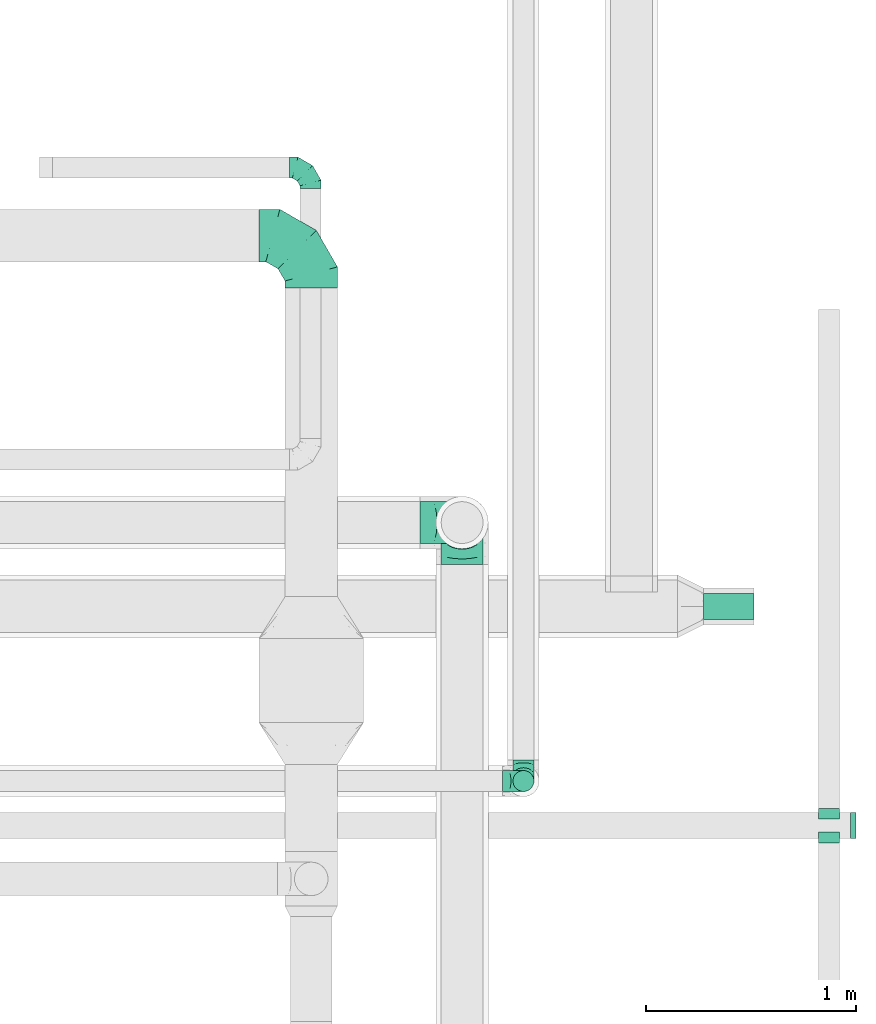
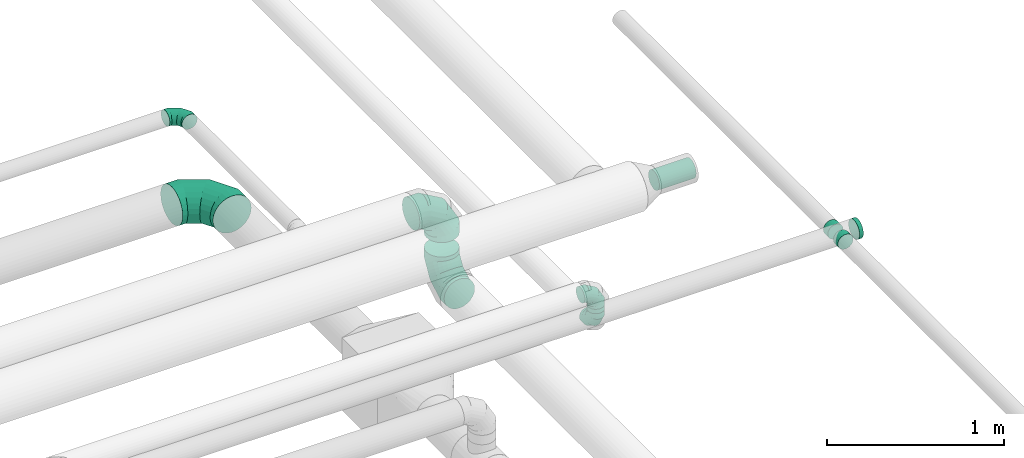
# One storey, part 82 of 92: 9 flow fittings, 2 flow segments.
"""IFC2X3 building model written with IfcOpenShell, lengths in millimetres."""

from ifc_helpers import new_model, entity, si_unit, converted_unit, derived_unit, direction, frame, origin, origin_2d_with_axis, place, context, subcontext, project, spatial, circle, extrude, faceted_brep, source, transform, mapped, material, type_object, type_shapes, element, save


model = new_model("IFC2X3")

# Units and contexts
model_context = context("Model", 3, precision=0.01, world=origin(), true_north=direction((6.12303176911189e-17, 1.0)))
body_context = subcontext(model_context, "Body", "Model", "MODEL_VIEW")
ifc_project = project(units=[si_unit("LENGTHUNIT", "METRE", prefix="MILLI"), si_unit("AREAUNIT", "SQUARE_METRE"), si_unit("VOLUMEUNIT", "CUBIC_METRE"), converted_unit("PLANEANGLEUNIT", "DEGREE", entity("IfcRatioMeasure", 0.0174532925199433), si_unit("PLANEANGLEUNIT", "RADIAN"), dimensions=[0, 0, 0, 0, 0, 0, 0]), si_unit("MASSUNIT", "GRAM", prefix="KILO"), derived_unit("MASSDENSITYUNIT", [(si_unit("MASSUNIT", "GRAM", prefix="KILO"), 1), (si_unit("LENGTHUNIT", "METRE"), -3)]), derived_unit("MOMENTOFINERTIAUNIT", [(si_unit("LENGTHUNIT", "METRE"), 4)]), si_unit("TIMEUNIT", "SECOND"), si_unit("FREQUENCYUNIT", "HERTZ"), si_unit("THERMODYNAMICTEMPERATUREUNIT", "DEGREE_CELSIUS"), derived_unit("THERMALTRANSMITTANCEUNIT", [(si_unit("MASSUNIT", "GRAM", prefix="KILO"), 1), (si_unit("THERMODYNAMICTEMPERATUREUNIT", "KELVIN"), -1), (si_unit("TIMEUNIT", "SECOND"), -3)]), derived_unit("VOLUMETRICFLOWRATEUNIT", [(si_unit("LENGTHUNIT", "METRE"), 3), (si_unit("TIMEUNIT", "SECOND"), -1)]), derived_unit("MASSFLOWRATEUNIT", [(si_unit("MASSUNIT", "GRAM", prefix="KILO"), 1), (si_unit("TIMEUNIT", "SECOND"), -1)]), derived_unit("ROTATIONALFREQUENCYUNIT", [(si_unit("TIMEUNIT", "SECOND"), -1)]), si_unit("ELECTRICCURRENTUNIT", "AMPERE"), si_unit("ELECTRICVOLTAGEUNIT", "VOLT"), si_unit("POWERUNIT", "WATT"), si_unit("FORCEUNIT", "NEWTON", prefix="KILO"), si_unit("ILLUMINANCEUNIT", "LUX"), si_unit("LUMINOUSFLUXUNIT", "LUMEN"), si_unit("LUMINOUSINTENSITYUNIT", "CANDELA"), derived_unit("USERDEFINED", [(si_unit("MASSUNIT", "GRAM", prefix="KILO"), -1), (si_unit("LENGTHUNIT", "METRE"), -2), (si_unit("TIMEUNIT", "SECOND"), 3), (si_unit("LUMINOUSFLUXUNIT", "LUMEN"), 1)]), derived_unit("LINEARVELOCITYUNIT", [(si_unit("LENGTHUNIT", "METRE"), 1), (si_unit("TIMEUNIT", "SECOND"), -1)]), si_unit("PRESSUREUNIT", "PASCAL"), derived_unit("USERDEFINED", [(si_unit("LENGTHUNIT", "METRE"), -2), (si_unit("MASSUNIT", "GRAM", prefix="KILO"), 1), (si_unit("TIMEUNIT", "SECOND"), -2)]), derived_unit("LINEARFORCEUNIT", [(si_unit("MASSUNIT", "GRAM", prefix="KILO"), 1), (si_unit("LENGTHUNIT", "METRE"), 1), (si_unit("TIMEUNIT", "SECOND"), -2), (si_unit("LENGTHUNIT", "METRE"), -1)]), derived_unit("PLANARFORCEUNIT", [(si_unit("MASSUNIT", "GRAM", prefix="KILO"), 1), (si_unit("LENGTHUNIT", "METRE"), 1), (si_unit("TIMEUNIT", "SECOND"), -2), (si_unit("LENGTHUNIT", "METRE"), -2)])], contexts=[model_context])

# Site, building, storey
site_placement = place(None, origin())
site = spatial("IfcSite", under=ifc_project, at=site_placement, CompositionType="ELEMENT")
building_placement = place(site_placement, origin())
building = spatial("IfcBuilding", under=site, at=building_placement, CompositionType="ELEMENT")
storey_placement = place(building_placement, frame((0.0, 0.0, 4200.0)))
storey = spatial("IfcBuildingStorey", under=building, at=storey_placement, CompositionType="ELEMENT", Elevation=4200.0)

# Flow segments
duct_segment_type_1 = type_object("IfcDuctSegmentType", PredefinedType="NOTDEFINED")
flow_segment_1_placement = place(storey_placement, frame((71802.08, 9511.08, 3235.9)))
element("IfcFlowSegment", 1, at=flow_segment_1_placement, inside=storey, type_object=duct_segment_type_1, context=body_context, shape_type="SweptSolid", body=[
    extrude(circle(Radius=62.5, at=origin_2d_with_axis()), frame((0.0, 64.1, 64.1), z_axis=(1.0, 0.0, 0.0), x_axis=(0.0, -1.0, 0.0)), (0.0, 0.0, 1.0), 239.999999999989),
])
duct_segment_type_2 = type_object("IfcDuctSegmentType", PredefinedType="NOTDEFINED")
flow_segment_2_placement = place(storey_placement, frame((70890.99, 8691.09, 3220.0)))
element("IfcFlowSegment", 2, at=flow_segment_2_placement, inside=storey, type_object=duct_segment_type_2, context=body_context, shape_type="SweptSolid", body=[
    extrude(circle(Radius=50.0, at=origin_2d_with_axis()), frame((51.6, 51.6, 0.0), z_axis=(0.0, 0.0, 1.0), x_axis=(0.0, 1.0, 0.0)), (0.0, 0.0, 1.0), 30.0000000000213),
])

# Flow fittings
ifc_material = material()
duct_fitting_type_1 = type_object("IfcDuctFittingType", PredefinedType="NOTDEFINED", material=ifc_material)
shared_shape_1 = source(origin(), body_context, "Body", "SweptSolid", [
    extrude(circle(Radius=62.4999999999996, at=origin_2d_with_axis()), frame((0.0, 0.0, 0.0), z_axis=(1.0, 0.0, 0.0), x_axis=(0.0, 1.0, 0.0)), (0.0, 0.0, 1.0), 25.0000000000018),
])
type_shapes(duct_fitting_type_1, [shared_shape_1])
flow_fitting_1_placement = place(storey_placement, frame((72502.75, 8530.14, 3350.0)))
element("IfcFlowFitting", 3, at=flow_fitting_1_placement, inside=storey, type_object=duct_fitting_type_1, material=ifc_material, context=body_context, shape_type="MappedRepresentation", body=[
    mapped(shared_shape_1, transform((0.0, 0.0, 0.0), scale=1.0)),
])
duct_fitting_type_2 = type_object("IfcDuctFittingType", PredefinedType="NOTDEFINED", material=ifc_material)
shared_shape_2 = source(origin(), body_context, "Body", "Brep", [
    faceted_brep([(-100.0, 0.0, -50.0), (-100.0, -12.94, -48.3), (-100.0, -25.0, -43.3), (-100.0, -35.36, -35.36), (-100.0, -43.3, -25.0), (-100.0, -48.3, -12.94), (-100.0, -50.0, 0.0), (-100.0, -48.3, 12.94), (-100.0, -43.3, 25.0), (-100.0, -35.36, 35.36), (-100.0, -25.0, 43.3), (-100.0, -12.94, 48.3), (-100.0, 0.0, 50.0), (-100.0, 12.94, 48.3), (-100.0, 25.0, 43.3), (-100.0, 35.36, 35.36), (-100.0, 43.3, 25.0), (-100.0, 48.3, 12.94), (-100.0, 50.0, 0.0), (-100.0, 48.3, -12.94), (-100.0, 43.3, -25.0), (-100.0, 35.36, -35.36), (-100.0, 25.0, -43.3), (-100.0, 12.94, -48.3), (-76.67, 12.94, 48.3), (-79.9, 25.0, 43.3), (-73.21, 0.0, 50.0), (-82.68, 35.36, 35.36), (-86.15, 48.3, 12.94), (-86.6, 50.0, 0.0), (-84.81, 43.3, 25.0), (-84.81, 43.3, -25.0), (-82.68, 35.36, -35.36), (-86.15, 48.3, -12.94), (-76.67, 12.94, -48.3), (-73.21, 0.0, -50.0), (-79.9, 25.0, -43.3), (-69.74, -12.94, -48.3), (-66.51, -25.0, -43.3), (-63.73, -35.36, -35.36), (-61.6, -43.3, -25.0), (-60.26, -48.3, -12.94), (-59.81, -50.0, 0.0), (-60.26, -48.3, 12.94), (-61.6, -43.3, 25.0), (-63.73, -35.36, 35.36), (-66.51, -25.0, 43.3), (-69.74, -12.94, 48.3), (-36.27, 36.27, 48.3), (-45.1, 45.1, 43.3), (-26.79, 26.79, 50.0), (-52.68, 52.68, 35.36), (-58.49, 58.49, 25.0), (-62.15, 62.15, 12.94), (-63.4, 63.4, 0.0), (-62.15, 62.15, -12.94), (-58.49, 58.49, -25.0), (-52.68, 52.68, -35.36), (-36.27, 36.27, -48.3), (-26.79, 26.79, -50.0), (-45.1, 45.1, -43.3), (-17.32, 17.32, -48.3), (-8.49, 8.49, -43.3), (-0.91, 0.91, -35.36), (4.9, -4.9, -25.0), (8.56, -8.56, -12.94), (9.81, -9.81, 0.0), (8.56, -8.56, 12.94), (4.9, -4.9, 25.0), (-0.91, 0.91, 35.36), (-8.49, 8.49, 43.3), (-17.32, 17.32, 48.3), (-12.94, 76.67, 48.3), (-25.0, 79.9, 43.3), (0.0, 73.21, 50.0), (-35.36, 82.68, 35.36), (-43.3, 84.81, 25.0), (-48.3, 86.15, 12.94), (-50.0, 86.6, 0.0), (-48.3, 86.15, -12.94), (-43.3, 84.81, -25.0), (-35.36, 82.68, -35.36), (-12.94, 76.67, -48.3), (0.0, 73.21, -50.0), (-25.0, 79.9, -43.3), (12.94, 69.74, -48.3), (25.0, 66.51, -43.3), (35.36, 63.73, -35.36), (43.3, 61.6, -25.0), (48.3, 60.26, -12.94), (50.0, 59.81, 0.0), (48.3, 60.26, 12.94), (43.3, 61.6, 25.0), (35.36, 63.73, 35.36), (25.0, 66.51, 43.3), (12.94, 69.74, 48.3), (-12.94, 100.0, -48.3), (-25.0, 100.0, -43.3), (-35.36, 100.0, -35.36), (-43.3, 100.0, -25.0), (-48.3, 100.0, -12.94), (-50.0, 100.0, 0.0), (-48.3, 100.0, 12.94), (-43.3, 100.0, 25.0), (-35.36, 100.0, 35.36), (-25.0, 100.0, 43.3), (-12.94, 100.0, 48.3), (0.0, 100.0, 50.0), (12.94, 100.0, 48.3), (25.0, 100.0, 43.3), (35.36, 100.0, 35.36), (43.3, 100.0, 25.0), (48.3, 100.0, 12.94), (50.0, 100.0, 0.0), (48.3, 100.0, -12.94), (43.3, 100.0, -25.0), (35.36, 100.0, -35.36), (25.0, 100.0, -43.3), (12.94, 100.0, -48.3), (0.0, 100.0, -50.0)], [[[0, 1, 2, 3, 4, 5, 6, 7, 8, 9, 10, 11, 12, 13, 14, 15, 16, 17, 18, 19, 20, 21, 22, 23]], [[24, 25, 14, 13]], [[26, 24, 13, 12]], [[14, 25, 27, 15]], [[28, 29, 18, 17]], [[30, 28, 17, 16]], [[15, 27, 30, 16]], [[20, 31, 32, 21]], [[33, 31, 20, 19]], [[18, 29, 33, 19]], [[34, 35, 0, 23]], [[36, 34, 23, 22]], [[32, 36, 22, 21]], [[2, 1, 37, 38]], [[3, 2, 38, 39]], [[0, 35, 37, 1]], [[5, 4, 40, 41]], [[6, 5, 41, 42]], [[3, 39, 40, 4]], [[6, 42, 43, 7]], [[7, 43, 44, 8]], [[8, 44, 45, 9]], [[10, 46, 47, 11]], [[11, 47, 26, 12]], [[10, 9, 45, 46]], [[48, 49, 25, 24]], [[50, 48, 24, 26]], [[27, 25, 49, 51]], [[52, 53, 28, 30]], [[51, 52, 30, 27]], [[29, 28, 53, 54]], [[55, 56, 31, 33]], [[54, 55, 33, 29]], [[57, 32, 31, 56]], [[58, 59, 35, 34]], [[60, 58, 34, 36]], [[57, 60, 36, 32]], [[37, 35, 59, 61]], [[38, 37, 61, 62]], [[39, 38, 62, 63]], [[41, 40, 64, 65]], [[42, 41, 65, 66]], [[63, 64, 40, 39]], [[43, 42, 66, 67]], [[44, 43, 67, 68]], [[68, 69, 45, 44]], [[46, 45, 69, 70]], [[47, 46, 70, 71]], [[26, 47, 71, 50]], [[72, 73, 49, 48]], [[74, 72, 48, 50]], [[51, 49, 73, 75]], [[76, 77, 53, 52]], [[75, 76, 52, 51]], [[54, 53, 77, 78]], [[79, 80, 56, 55]], [[78, 79, 55, 54]], [[81, 57, 56, 80]], [[82, 83, 59, 58]], [[84, 82, 58, 60]], [[81, 84, 60, 57]], [[61, 59, 83, 85]], [[62, 61, 85, 86]], [[63, 62, 86, 87]], [[65, 64, 88, 89]], [[66, 65, 89, 90]], [[87, 88, 64, 63]], [[67, 66, 90, 91]], [[68, 67, 91, 92]], [[92, 93, 69, 68]], [[70, 69, 93, 94]], [[71, 70, 94, 95]], [[50, 71, 95, 74]], [[96, 97, 98, 99, 100, 101, 102, 103, 104, 105, 106, 107, 108, 109, 110, 111, 112, 113, 114, 115, 116, 117, 118, 119]], [[72, 74, 107, 106]], [[73, 72, 106, 105]], [[75, 73, 105, 104]], [[77, 76, 103, 102]], [[78, 77, 102, 101]], [[75, 104, 103, 76]], [[78, 101, 100, 79]], [[79, 100, 99, 80]], [[80, 99, 98, 81]], [[96, 119, 83, 82]], [[97, 96, 82, 84]], [[84, 81, 98, 97]], [[83, 119, 118, 85]], [[85, 118, 117, 86]], [[86, 117, 116, 87]], [[88, 115, 114, 89]], [[89, 114, 113, 90]], [[87, 116, 115, 88]], [[91, 90, 113, 112]], [[92, 91, 112, 111]], [[93, 92, 111, 110]], [[95, 94, 109, 108]], [[74, 95, 108, 107]], [[110, 109, 94, 93]]]),
])
type_shapes(duct_fitting_type_2, [shared_shape_2])
for number, where, z_axis, x_axis in (
    (4, (70942.58, 8742.68, 3120.0), (-1.0, 0.0, 0.0), (0.0, -1.0, 0.0)),
    (5, (70942.58, 8742.68, 3350.0), (0.0, -1.0, 0.0), (0.0, 0.0, 1.0)),
    (6, (69927.09, 11667.58, 3150.0), (0.0, 0.0, 1.0), (0.0, 1.0, 0.0)),
):
    element("IfcFlowFitting", number, at=place(storey_placement, frame(where, z_axis=z_axis, x_axis=x_axis)), inside=storey, type_object=duct_fitting_type_2, material=ifc_material, context=body_context, shape_type="MappedRepresentation", body=[
        mapped(shared_shape_2, transform((0.0, 0.0, 0.0), scale=1.0)),
    ])
duct_fitting_type_3 = type_object("IfcDuctFittingType", PredefinedType="NOTDEFINED", material=ifc_material)
shared_shape_3 = source(origin(), body_context, "Body", "Brep", [
    faceted_brep([(-250.0, 0.0, -125.0), (-250.0, -32.35, -120.74), (-250.0, -62.5, -108.25), (-250.0, -88.39, -88.39), (-250.0, -108.25, -62.5), (-250.0, -120.74, -32.35), (-250.0, -125.0, 0.0), (-250.0, -120.74, 32.35), (-250.0, -108.25, 62.5), (-250.0, -88.39, 88.39), (-250.0, -62.5, 108.25), (-250.0, -32.35, 120.74), (-250.0, 0.0, 125.0), (-250.0, 32.35, 120.74), (-250.0, 62.5, 108.25), (-250.0, 88.39, 88.39), (-250.0, 108.25, 62.5), (-250.0, 120.74, 32.35), (-250.0, 125.0, 0.0), (-250.0, 120.74, -32.35), (-250.0, 108.25, -62.5), (-250.0, 88.39, -88.39), (-250.0, 62.5, -108.25), (-250.0, 32.35, -120.74), (-191.68, 32.35, 120.74), (-199.76, 62.5, 108.25), (-183.01, 0.0, 125.0), (-206.7, 88.39, 88.39), (-215.37, 120.74, 32.35), (-216.51, 125.0, 0.0), (-212.02, 108.25, 62.5), (-212.02, 108.25, -62.5), (-206.7, 88.39, -88.39), (-215.37, 120.74, -32.35), (-191.68, 32.35, -120.74), (-183.01, 0.0, -125.0), (-199.76, 62.5, -108.25), (-174.34, -32.35, -120.74), (-166.27, -62.5, -108.25), (-159.33, -88.39, -88.39), (-154.01, -108.25, -62.5), (-150.66, -120.74, -32.35), (-149.52, -125.0, 0.0), (-150.66, -120.74, 32.35), (-154.01, -108.25, 62.5), (-159.33, -88.39, 88.39), (-166.27, -62.5, 108.25), (-174.34, -32.35, 120.74), (-90.67, 90.67, 120.74), (-112.74, 112.74, 108.25), (-66.99, 66.99, 125.0), (-131.69, 131.69, 88.39), (-146.23, 146.23, 62.5), (-155.38, 155.38, 32.35), (-158.49, 158.49, 0.0), (-155.38, 155.38, -32.35), (-146.23, 146.23, -62.5), (-131.69, 131.69, -88.39), (-90.67, 90.67, -120.74), (-66.99, 66.99, -125.0), (-112.74, 112.74, -108.25), (-43.3, 43.3, -120.74), (-21.23, 21.23, -108.25), (-2.28, 2.28, -88.39), (12.26, -12.26, -62.5), (21.4, -21.4, -32.35), (24.52, -24.52, 0.0), (21.4, -21.4, 32.35), (12.26, -12.26, 62.5), (-2.28, 2.28, 88.39), (-21.23, 21.23, 108.25), (-43.3, 43.3, 120.74), (-32.35, 191.68, 120.74), (-62.5, 199.76, 108.25), (0.0, 183.01, 125.0), (-88.39, 206.7, 88.39), (-108.25, 212.02, 62.5), (-120.74, 215.37, 32.35), (-125.0, 216.51, 0.0), (-120.74, 215.37, -32.35), (-108.25, 212.02, -62.5), (-88.39, 206.7, -88.39), (-32.35, 191.68, -120.74), (0.0, 183.01, -125.0), (-62.5, 199.76, -108.25), (32.35, 174.34, -120.74), (62.5, 166.27, -108.25), (88.39, 159.33, -88.39), (108.25, 154.01, -62.5), (120.74, 150.66, -32.35), (125.0, 149.52, 0.0), (120.74, 150.66, 32.35), (108.25, 154.01, 62.5), (88.39, 159.33, 88.39), (62.5, 166.27, 108.25), (32.35, 174.34, 120.74), (-32.35, 250.0, -120.74), (-62.5, 250.0, -108.25), (-88.39, 250.0, -88.39), (-108.25, 250.0, -62.5), (-120.74, 250.0, -32.35), (-125.0, 250.0, 0.0), (-120.74, 250.0, 32.35), (-108.25, 250.0, 62.5), (-88.39, 250.0, 88.39), (-62.5, 250.0, 108.25), (-32.35, 250.0, 120.74), (0.0, 250.0, 125.0), (32.35, 250.0, 120.74), (62.5, 250.0, 108.25), (88.39, 250.0, 88.39), (108.25, 250.0, 62.5), (120.74, 250.0, 32.35), (125.0, 250.0, 0.0), (120.74, 250.0, -32.35), (108.25, 250.0, -62.5), (88.39, 250.0, -88.39), (62.5, 250.0, -108.25), (32.35, 250.0, -120.74), (0.0, 250.0, -125.0)], [[[0, 1, 2, 3, 4, 5, 6, 7, 8, 9, 10, 11, 12, 13, 14, 15, 16, 17, 18, 19, 20, 21, 22, 23]], [[24, 25, 14, 13]], [[26, 24, 13, 12]], [[14, 25, 27, 15]], [[28, 29, 18, 17]], [[30, 28, 17, 16]], [[15, 27, 30, 16]], [[20, 31, 32, 21]], [[33, 31, 20, 19]], [[18, 29, 33, 19]], [[34, 35, 0, 23]], [[36, 34, 23, 22]], [[21, 32, 36, 22]], [[1, 0, 35, 37]], [[2, 1, 37, 38]], [[38, 39, 3, 2]], [[5, 4, 40, 41]], [[6, 5, 41, 42]], [[39, 40, 4, 3]], [[6, 42, 43, 7]], [[7, 43, 44, 8]], [[8, 44, 45, 9]], [[9, 45, 46, 10]], [[10, 46, 47, 11]], [[26, 12, 11, 47]], [[48, 49, 25, 24]], [[50, 48, 24, 26]], [[27, 25, 49, 51]], [[52, 53, 28, 30]], [[51, 52, 30, 27]], [[29, 28, 53, 54]], [[55, 56, 31, 33]], [[54, 55, 33, 29]], [[32, 31, 56, 57]], [[58, 59, 35, 34]], [[60, 58, 34, 36]], [[57, 60, 36, 32]], [[37, 35, 59, 61]], [[38, 37, 61, 62]], [[39, 38, 62, 63]], [[41, 40, 64, 65]], [[42, 41, 65, 66]], [[63, 64, 40, 39]], [[43, 42, 66, 67]], [[44, 43, 67, 68]], [[68, 69, 45, 44]], [[46, 45, 69, 70]], [[47, 46, 70, 71]], [[26, 47, 71, 50]], [[72, 73, 49, 48]], [[74, 72, 48, 50]], [[51, 49, 73, 75]], [[76, 77, 53, 52]], [[75, 76, 52, 51]], [[54, 53, 77, 78]], [[79, 80, 56, 55]], [[78, 79, 55, 54]], [[57, 56, 80, 81]], [[82, 83, 59, 58]], [[84, 82, 58, 60]], [[81, 84, 60, 57]], [[61, 59, 83, 85]], [[62, 61, 85, 86]], [[63, 62, 86, 87]], [[65, 64, 88, 89]], [[66, 65, 89, 90]], [[87, 88, 64, 63]], [[67, 66, 90, 91]], [[68, 67, 91, 92]], [[92, 93, 69, 68]], [[70, 69, 93, 94]], [[71, 70, 94, 95]], [[50, 71, 95, 74]], [[96, 97, 98, 99, 100, 101, 102, 103, 104, 105, 106, 107, 108, 109, 110, 111, 112, 113, 114, 115, 116, 117, 118, 119]], [[72, 74, 107, 106]], [[73, 72, 106, 105]], [[75, 73, 105, 104]], [[77, 76, 103, 102]], [[78, 77, 102, 101]], [[75, 104, 103, 76]], [[78, 101, 100, 79]], [[79, 100, 99, 80]], [[80, 99, 98, 81]], [[84, 97, 96, 82]], [[82, 96, 119, 83]], [[84, 81, 98, 97]], [[83, 119, 118, 85]], [[85, 118, 117, 86]], [[116, 87, 86, 117]], [[88, 115, 114, 89]], [[89, 114, 113, 90]], [[115, 88, 87, 116]], [[91, 90, 113, 112]], [[92, 91, 112, 111]], [[111, 110, 93, 92]], [[95, 94, 109, 108]], [[74, 95, 108, 107]], [[110, 109, 94, 93]]]),
])
type_shapes(duct_fitting_type_3, [shared_shape_3])
flow_fitting_2_placement = place(storey_placement, frame((69930.58, 11343.71, 2800.0), z_axis=(0.0, 0.0, 1.0), x_axis=(0.0, 1.0, 0.0)))
element("IfcFlowFitting", 7, at=flow_fitting_2_placement, inside=storey, type_object=duct_fitting_type_3, material=ifc_material, context=body_context, shape_type="MappedRepresentation", body=[
    mapped(shared_shape_3, transform((0.0, 0.0, 0.0), scale=1.0)),
])
duct_fitting_type_4 = type_object("IfcDuctFittingType", PredefinedType="NOTDEFINED", material=ifc_material)
shared_shape_4 = source(origin(), body_context, "Body", "Brep", [
    faceted_brep([(-200.0, 0.0, -100.0), (-200.0, -25.88, -96.59), (-200.0, -50.0, -86.6), (-200.0, -70.71, -70.71), (-200.0, -86.6, -50.0), (-200.0, -96.59, -25.88), (-200.0, -100.0, 0.0), (-200.0, -96.59, 25.88), (-200.0, -86.6, 50.0), (-200.0, -70.71, 70.71), (-200.0, -50.0, 86.6), (-200.0, -25.88, 96.59), (-200.0, 0.0, 100.0), (-200.0, 25.88, 96.59), (-200.0, 50.0, 86.6), (-200.0, 70.71, 70.71), (-200.0, 86.6, 50.0), (-200.0, 96.59, 25.88), (-200.0, 100.0, 0.0), (-200.0, 96.59, -25.88), (-200.0, 86.6, -50.0), (-200.0, 70.71, -70.71), (-200.0, 50.0, -86.6), (-200.0, 25.88, -96.59), (-153.35, 25.88, 96.59), (-159.81, 50.0, 86.6), (-146.41, 0.0, 100.0), (-165.36, 70.71, 70.71), (-172.29, 96.59, 25.88), (-173.21, 100.0, 0.0), (-169.62, 86.6, 50.0), (-169.62, 86.6, -50.0), (-165.36, 70.71, -70.71), (-172.29, 96.59, -25.88), (-153.35, 25.88, -96.59), (-146.41, 0.0, -100.0), (-159.81, 50.0, -86.6), (-139.48, -25.88, -96.59), (-133.01, -50.0, -86.6), (-127.46, -70.71, -70.71), (-123.21, -86.6, -50.0), (-120.53, -96.59, -25.88), (-119.62, -100.0, 0.0), (-120.53, -96.59, 25.88), (-123.21, -86.6, 50.0), (-127.46, -70.71, 70.71), (-133.01, -50.0, 86.6), (-139.48, -25.88, 96.59), (-72.54, 72.54, 96.59), (-90.19, 90.19, 86.6), (-53.59, 53.59, 100.0), (-105.35, 105.35, 70.71), (-116.99, 116.99, 50.0), (-124.3, 124.3, 25.88), (-126.79, 126.79, 0.0), (-124.3, 124.3, -25.88), (-116.99, 116.99, -50.0), (-105.35, 105.35, -70.71), (-72.54, 72.54, -96.59), (-53.59, 53.59, -100.0), (-90.19, 90.19, -86.6), (-34.64, 34.64, -96.59), (-16.99, 16.99, -86.6), (-1.83, 1.83, -70.71), (9.81, -9.81, -50.0), (17.12, -17.12, -25.88), (19.62, -19.62, 0.0), (17.12, -17.12, 25.88), (9.81, -9.81, 50.0), (-1.83, 1.83, 70.71), (-16.99, 16.99, 86.6), (-34.64, 34.64, 96.59), (-25.88, 153.35, 96.59), (-50.0, 159.81, 86.6), (0.0, 146.41, 100.0), (-70.71, 165.36, 70.71), (-86.6, 169.62, 50.0), (-96.59, 172.29, 25.88), (-100.0, 173.21, 0.0), (-96.59, 172.29, -25.88), (-86.6, 169.62, -50.0), (-70.71, 165.36, -70.71), (-25.88, 153.35, -96.59), (0.0, 146.41, -100.0), (-50.0, 159.81, -86.6), (25.88, 139.48, -96.59), (50.0, 133.01, -86.6), (70.71, 127.46, -70.71), (86.6, 123.21, -50.0), (96.59, 120.53, -25.88), (100.0, 119.62, 0.0), (96.59, 120.53, 25.88), (86.6, 123.21, 50.0), (70.71, 127.46, 70.71), (50.0, 133.01, 86.6), (25.88, 139.48, 96.59), (-25.88, 200.0, -96.59), (-50.0, 200.0, -86.6), (-70.71, 200.0, -70.71), (-86.6, 200.0, -50.0), (-96.59, 200.0, -25.88), (-100.0, 200.0, 0.0), (-96.59, 200.0, 25.88), (-86.6, 200.0, 50.0), (-70.71, 200.0, 70.71), (-50.0, 200.0, 86.6), (-25.88, 200.0, 96.59), (0.0, 200.0, 100.0), (25.88, 200.0, 96.59), (50.0, 200.0, 86.6), (70.71, 200.0, 70.71), (86.6, 200.0, 50.0), (96.59, 200.0, 25.88), (100.0, 200.0, 0.0), (96.59, 200.0, -25.88), (86.6, 200.0, -50.0), (70.71, 200.0, -70.71), (50.0, 200.0, -86.6), (25.88, 200.0, -96.59), (0.0, 200.0, -100.0)], [[[0, 1, 2, 3, 4, 5, 6, 7, 8, 9, 10, 11, 12, 13, 14, 15, 16, 17, 18, 19, 20, 21, 22, 23]], [[24, 25, 14, 13]], [[26, 24, 13, 12]], [[14, 25, 27, 15]], [[28, 29, 18, 17]], [[30, 28, 17, 16]], [[15, 27, 30, 16]], [[20, 31, 32, 21]], [[33, 31, 20, 19]], [[18, 29, 33, 19]], [[34, 35, 0, 23]], [[36, 34, 23, 22]], [[32, 36, 22, 21]], [[1, 0, 35, 37]], [[2, 1, 37, 38]], [[38, 39, 3, 2]], [[5, 4, 40, 41]], [[6, 5, 41, 42]], [[39, 40, 4, 3]], [[6, 42, 43, 7]], [[7, 43, 44, 8]], [[8, 44, 45, 9]], [[9, 45, 46, 10]], [[10, 46, 47, 11]], [[26, 12, 11, 47]], [[48, 49, 25, 24]], [[50, 48, 24, 26]], [[27, 25, 49, 51]], [[52, 53, 28, 30]], [[51, 52, 30, 27]], [[29, 28, 53, 54]], [[55, 56, 31, 33]], [[54, 55, 33, 29]], [[32, 31, 56, 57]], [[58, 59, 35, 34]], [[60, 58, 34, 36]], [[57, 60, 36, 32]], [[37, 35, 59, 61]], [[38, 37, 61, 62]], [[39, 38, 62, 63]], [[41, 40, 64, 65]], [[42, 41, 65, 66]], [[63, 64, 40, 39]], [[43, 42, 66, 67]], [[44, 43, 67, 68]], [[68, 69, 45, 44]], [[46, 45, 69, 70]], [[47, 46, 70, 71]], [[26, 47, 71, 50]], [[72, 73, 49, 48]], [[74, 72, 48, 50]], [[51, 49, 73, 75]], [[76, 77, 53, 52]], [[75, 76, 52, 51]], [[54, 53, 77, 78]], [[79, 80, 56, 55]], [[78, 79, 55, 54]], [[57, 56, 80, 81]], [[82, 83, 59, 58]], [[84, 82, 58, 60]], [[81, 84, 60, 57]], [[61, 59, 83, 85]], [[62, 61, 85, 86]], [[63, 62, 86, 87]], [[65, 64, 88, 89]], [[66, 65, 89, 90]], [[87, 88, 64, 63]], [[67, 66, 90, 91]], [[68, 67, 91, 92]], [[92, 93, 69, 68]], [[70, 69, 93, 94]], [[71, 70, 94, 95]], [[50, 71, 95, 74]], [[96, 97, 98, 99, 100, 101, 102, 103, 104, 105, 106, 107, 108, 109, 110, 111, 112, 113, 114, 115, 116, 117, 118, 119]], [[72, 74, 107, 106]], [[73, 72, 106, 105]], [[75, 73, 105, 104]], [[102, 101, 78, 77]], [[103, 102, 77, 76]], [[75, 104, 103, 76]], [[78, 101, 100, 79]], [[79, 100, 99, 80]], [[80, 99, 98, 81]], [[84, 97, 96, 82]], [[82, 96, 119, 83]], [[84, 81, 98, 97]], [[118, 117, 86, 85]], [[119, 118, 85, 83]], [[116, 87, 86, 117]], [[88, 115, 114, 89]], [[89, 114, 113, 90]], [[115, 88, 87, 116]], [[91, 90, 113, 112]], [[92, 91, 112, 111]], [[111, 110, 93, 92]], [[95, 94, 109, 108]], [[74, 95, 108, 107]], [[110, 109, 94, 93]]]),
])
type_shapes(duct_fitting_type_4, [shared_shape_4])
for number, where, z_axis, x_axis in (
    (8, (70650.06, 9974.93, 2800.0), (1.0, 0.0, 0.0), (0.0, 1.0, 0.0)),
    (9, (70650.06, 9974.93, 3300.0), (0.0, -1.0, 0.0), (0.0, 0.0, 1.0)),
):
    element("IfcFlowFitting", number, at=place(storey_placement, frame(where, z_axis=z_axis, x_axis=x_axis)), inside=storey, type_object=duct_fitting_type_4, material=ifc_material, context=body_context, shape_type="MappedRepresentation", body=[
        mapped(shared_shape_4, transform((0.0, 0.0, 0.0), scale=1.0)),
    ])
duct_fitting_type_5 = type_object("IfcDuctFittingType", PredefinedType="NOTDEFINED", material=ifc_material)
shared_shape_5 = source(origin(), body_context, "Body", "Brep", [
    faceted_brep([(20.0, 12.94, -48.3), (20.0, 25.0, -43.3), (20.0, 35.36, -35.36), (20.0, 43.3, -25.0), (20.0, 48.3, -12.94), (20.0, 50.0, 0.0), (20.0, 48.3, 12.94), (20.0, 43.3, 25.0), (20.0, 35.36, 35.36), (20.0, 25.0, 43.3), (20.0, 12.94, 48.3), (20.0, 0.0, 50.0), (20.0, -12.94, 48.3), (20.0, -25.0, 43.3), (20.0, -35.36, 35.36), (20.0, -43.3, 25.0), (20.0, -48.3, 12.94), (20.0, -50.0, 0.0), (20.0, -48.3, -12.94), (20.0, -43.3, -25.0), (20.0, -35.36, -35.36), (20.0, -25.0, -43.3), (20.0, -12.94, -48.3), (20.0, 0.0, -50.0), (0.0, 0.0, 50.0), (0.0, 12.94, 48.3), (-31.1, 12.94, 48.3), (-31.1, 0.0, 50.0), (0.0, 25.0, 43.3), (-31.1, 25.0, 43.3), (0.0, 35.36, 35.36), (-31.1, 35.36, 35.36), (0.0, 43.3, 25.0), (0.0, 48.3, 12.94), (-31.1, 48.3, 12.94), (-31.1, 43.3, 25.0), (0.0, 50.0, 0.0), (-31.1, 50.0, 0.0), (0.0, 48.3, -12.94), (-31.1, 48.3, -12.94), (0.0, 43.3, -25.0), (-31.1, 43.3, -25.0), (0.0, 35.36, -35.36), (-31.1, 35.36, -35.36), (0.0, 25.0, -43.3), (0.0, 12.94, -48.3), (-31.1, 12.94, -48.3), (-31.1, 25.0, -43.3), (0.0, 0.0, -50.0), (-31.1, 0.0, -50.0), (0.0, -12.94, -48.3), (-31.1, -12.94, -48.3), (0.0, -25.0, -43.3), (-31.1, -25.0, -43.3), (0.0, -35.36, -35.36), (-31.1, -35.36, -35.36), (0.0, -43.3, -25.0), (0.0, -48.3, -12.94), (-31.1, -48.3, -12.94), (-31.1, -43.3, -25.0), (0.0, -50.0, 0.0), (-31.1, -50.0, 0.0), (0.0, -48.3, 12.94), (-31.1, -48.3, 12.94), (0.0, -43.3, 25.0), (-31.1, -43.3, 25.0), (0.0, -35.36, 35.36), (-31.1, -35.36, 35.36), (0.0, -25.0, 43.3), (0.0, -12.94, 48.3), (-31.1, -12.94, 48.3), (-31.1, -25.0, 43.3)], [[[0, 1, 2, 3, 4, 5, 6, 7, 8, 9, 10, 11, 12, 13, 14, 15, 16, 17, 18, 19, 20, 21, 22, 23]], [[24, 11, 10, 25, 26, 27]], [[25, 10, 9, 28, 29, 26]], [[28, 9, 8, 30, 31, 29]], [[32, 7, 6, 33, 34, 35]], [[33, 6, 5, 36, 37, 34]], [[30, 8, 7, 32, 35, 31]], [[36, 5, 4, 38, 39, 37]], [[38, 4, 3, 40, 41, 39]], [[40, 3, 2, 42, 43, 41]], [[44, 1, 0, 45, 46, 47]], [[45, 0, 23, 48, 49, 46]], [[42, 2, 1, 44, 47, 43]], [[48, 23, 22, 50, 51, 49]], [[50, 22, 21, 52, 53, 51]], [[52, 21, 20, 54, 55, 53]], [[56, 19, 18, 57, 58, 59]], [[57, 18, 17, 60, 61, 58]], [[54, 20, 19, 56, 59, 55]], [[60, 17, 16, 62, 63, 61]], [[62, 16, 15, 64, 65, 63]], [[64, 15, 14, 66, 67, 65]], [[68, 13, 12, 69, 70, 71]], [[69, 12, 11, 24, 27, 70]], [[66, 14, 13, 68, 71, 67]], [[49, 51, 53, 55, 59, 58, 61, 63, 65, 67, 71, 70, 27, 26, 29, 31, 35, 34, 37, 39, 41, 43, 47, 46]]]),
])
type_shapes(duct_fitting_type_5, [shared_shape_5])
flow_fitting_3_placement = place(storey_placement, frame((72399.56, 8467.64, 3350.0), z_axis=(0.0, 0.0, -1.0), x_axis=(0.0, -1.0, 0.0)))
element("IfcFlowFitting", 10, at=flow_fitting_3_placement, inside=storey, type_object=duct_fitting_type_5, material=ifc_material, context=body_context, shape_type="MappedRepresentation", body=[
    mapped(shared_shape_5, transform((0.0, 0.0, 0.0), scale=1.0)),
])
duct_fitting_type_6 = type_object("IfcDuctFittingType", PredefinedType="NOTDEFINED", material=ifc_material)
shared_shape_6 = source(origin(), body_context, "Body", "Brep", [
    faceted_brep([(20.0, 0.0, -50.0), (20.0, 12.94, -48.3), (20.0, 25.0, -43.3), (20.0, 35.36, -35.36), (20.0, 43.3, -25.0), (20.0, 48.3, -12.94), (20.0, 50.0, 0.0), (20.0, 48.3, 12.94), (20.0, 43.3, 25.0), (20.0, 35.36, 35.36), (20.0, 25.0, 43.3), (20.0, 12.94, 48.3), (20.0, 0.0, 50.0), (20.0, -12.94, 48.3), (20.0, -25.0, 43.3), (20.0, -35.36, 35.36), (20.0, -43.3, 25.0), (20.0, -48.3, 12.94), (20.0, -50.0, 0.0), (20.0, -48.3, -12.94), (20.0, -43.3, -25.0), (20.0, -35.36, -35.36), (20.0, -25.0, -43.3), (20.0, -12.94, -48.3), (0.0, 0.0, 50.0), (-31.1, 0.0, 50.0), (-31.1, -12.94, 48.3), (0.0, -12.94, 48.3), (-31.1, -25.0, 43.3), (0.0, -25.0, 43.3), (0.0, -35.36, 35.36), (-31.1, -35.36, 35.36), (0.0, -43.3, 25.0), (-31.1, -43.3, 25.0), (-31.1, -48.3, 12.94), (0.0, -48.3, 12.94), (-31.1, -50.0, 0.0), (0.0, -50.0, 0.0), (-31.1, -48.3, -12.94), (0.0, -48.3, -12.94), (-31.1, -43.3, -25.0), (0.0, -43.3, -25.0), (0.0, -35.36, -35.36), (-31.1, -35.36, -35.36), (0.0, -25.0, -43.3), (-31.1, -25.0, -43.3), (-31.1, -12.94, -48.3), (0.0, -12.94, -48.3), (-31.1, 0.0, -50.0), (0.0, 0.0, -50.0), (-31.1, 12.94, -48.3), (0.0, 12.94, -48.3), (-31.1, 25.0, -43.3), (0.0, 25.0, -43.3), (0.0, 35.36, -35.36), (-31.1, 35.36, -35.36), (0.0, 43.3, -25.0), (-31.1, 43.3, -25.0), (-31.1, 48.3, -12.94), (0.0, 48.3, -12.94), (-31.1, 50.0, 0.0), (0.0, 50.0, 0.0), (-31.1, 48.3, 12.94), (0.0, 48.3, 12.94), (-31.1, 43.3, 25.0), (0.0, 43.3, 25.0), (0.0, 35.36, 35.36), (-31.1, 35.36, 35.36), (0.0, 25.0, 43.3), (-31.1, 25.0, 43.3), (-31.1, 12.94, 48.3), (0.0, 12.94, 48.3)], [[[0, 1, 2, 3, 4, 5, 6, 7, 8, 9, 10, 11, 12, 13, 14, 15, 16, 17, 18, 19, 20, 21, 22, 23]], [[13, 12, 24, 25, 26, 27]], [[14, 13, 27, 26, 28, 29]], [[30, 15, 14, 29, 28, 31]], [[17, 16, 32, 33, 34, 35]], [[18, 17, 35, 34, 36, 37]], [[32, 16, 15, 30, 31, 33]], [[19, 18, 37, 36, 38, 39]], [[20, 19, 39, 38, 40, 41]], [[42, 21, 20, 41, 40, 43]], [[23, 22, 44, 45, 46, 47]], [[0, 23, 47, 46, 48, 49]], [[44, 22, 21, 42, 43, 45]], [[1, 0, 49, 48, 50, 51]], [[2, 1, 51, 50, 52, 53]], [[54, 3, 2, 53, 52, 55]], [[5, 4, 56, 57, 58, 59]], [[6, 5, 59, 58, 60, 61]], [[56, 4, 3, 54, 55, 57]], [[7, 6, 61, 60, 62, 63]], [[8, 7, 63, 62, 64, 65]], [[66, 9, 8, 65, 64, 67]], [[11, 10, 68, 69, 70, 71]], [[12, 11, 71, 70, 25, 24]], [[68, 10, 9, 66, 67, 69]], [[46, 45, 43, 40, 38, 36, 34, 33, 31, 28, 26, 25, 70, 69, 67, 64, 62, 60, 58, 57, 55, 52, 50, 48]]]),
])
type_shapes(duct_fitting_type_6, [shared_shape_6])
flow_fitting_4_placement = place(storey_placement, frame((72399.56, 8592.64, 3350.0), z_axis=(0.0, 0.0, -1.0), x_axis=(0.0, 1.0, 0.0)))
element("IfcFlowFitting", 11, at=flow_fitting_4_placement, inside=storey, type_object=duct_fitting_type_6, material=ifc_material, context=body_context, shape_type="MappedRepresentation", body=[
    mapped(shared_shape_6, transform((0.0, 0.0, 0.0), scale=1.0)),
])

save(model, "model.ifc")
